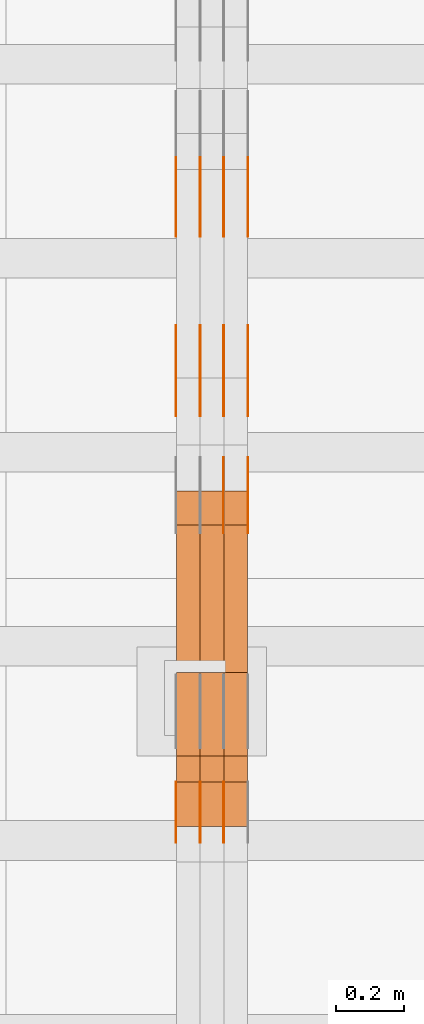
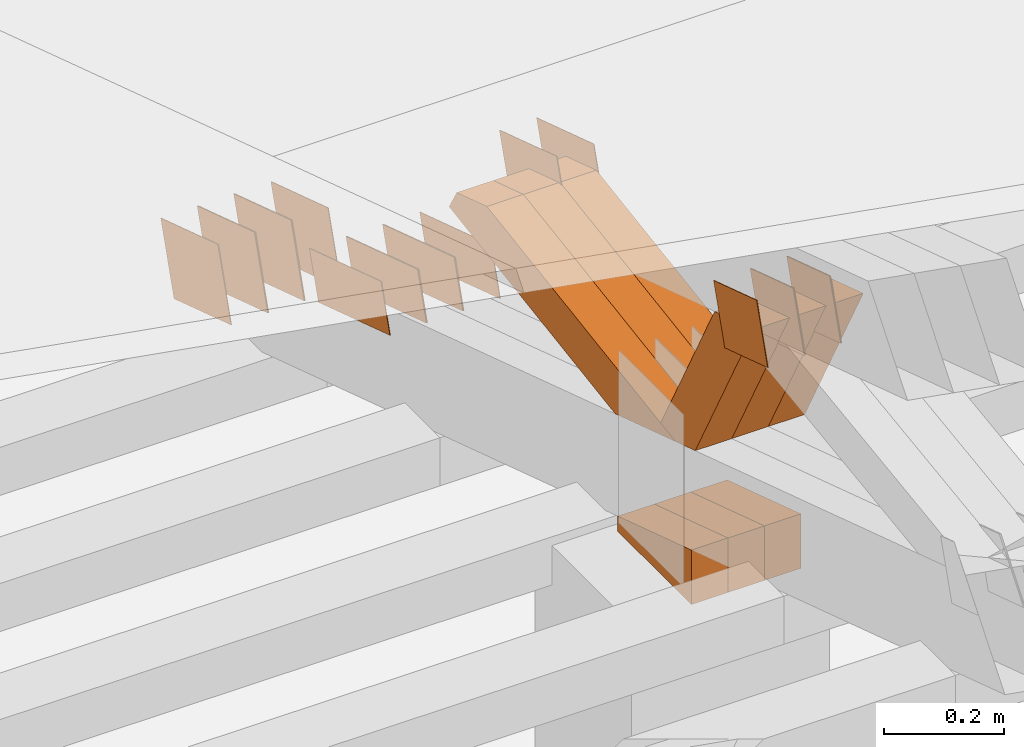
# One storey, part 168 of 385: 28 proxies.
"""IFC2X3 building model written with IfcOpenShell, lengths in millimetres."""

from ifc_helpers import new_model, entity, si_unit, converted_unit, derived_unit, direction, frame, origin, place, context, subcontext, project, spatial, polyline, outline, extrude, source, transform, mapped, material, type_object, type_shapes, element, save


model = new_model("IFC2X3")

# Units and contexts
model_context = context("Model", 3, precision=0.01, world=origin(), true_north=direction((6.12303176911189e-17, 1.0)))
body_context = subcontext(model_context, "Body", "Model", "MODEL_VIEW")
ifc_project = project(units=[si_unit("LENGTHUNIT", "METRE", prefix="MILLI"), si_unit("AREAUNIT", "SQUARE_METRE"), si_unit("VOLUMEUNIT", "CUBIC_METRE"), converted_unit("PLANEANGLEUNIT", "DEGREE", entity("IfcRatioMeasure", 0.0174532925199433), si_unit("PLANEANGLEUNIT", "RADIAN"), dimensions=[0, 0, 0, 0, 0, 0, 0]), si_unit("MASSUNIT", "GRAM", prefix="KILO"), derived_unit("MASSDENSITYUNIT", [(si_unit("MASSUNIT", "GRAM", prefix="KILO"), 1), (si_unit("LENGTHUNIT", "METRE"), -3)]), si_unit("TIMEUNIT", "SECOND"), si_unit("FREQUENCYUNIT", "HERTZ"), si_unit("THERMODYNAMICTEMPERATUREUNIT", "DEGREE_CELSIUS"), derived_unit("THERMALTRANSMITTANCEUNIT", [(si_unit("MASSUNIT", "GRAM", prefix="KILO"), 1), (si_unit("THERMODYNAMICTEMPERATUREUNIT", "KELVIN"), -1), (si_unit("TIMEUNIT", "SECOND"), -3)]), derived_unit("VOLUMETRICFLOWRATEUNIT", [(si_unit("LENGTHUNIT", "METRE"), 3), (si_unit("TIMEUNIT", "SECOND"), -1)]), si_unit("ELECTRICCURRENTUNIT", "AMPERE"), si_unit("ELECTRICVOLTAGEUNIT", "VOLT"), si_unit("POWERUNIT", "WATT"), si_unit("FORCEUNIT", "NEWTON", prefix="KILO"), si_unit("ILLUMINANCEUNIT", "LUX"), si_unit("LUMINOUSFLUXUNIT", "LUMEN"), si_unit("LUMINOUSINTENSITYUNIT", "CANDELA"), derived_unit("USERDEFINED", [(si_unit("MASSUNIT", "GRAM", prefix="KILO"), -1), (si_unit("LENGTHUNIT", "METRE"), -2), (si_unit("TIMEUNIT", "SECOND"), 3), (si_unit("LUMINOUSFLUXUNIT", "LUMEN"), 1)]), derived_unit("LINEARVELOCITYUNIT", [(si_unit("LENGTHUNIT", "METRE"), 1), (si_unit("TIMEUNIT", "SECOND"), -1)]), si_unit("PRESSUREUNIT", "PASCAL"), derived_unit("USERDEFINED", [(si_unit("LENGTHUNIT", "METRE"), -2), (si_unit("MASSUNIT", "GRAM", prefix="KILO"), 1), (si_unit("TIMEUNIT", "SECOND"), -2)])], contexts=[model_context])

# Site, building, storey
site_placement = place(None, origin())
site = spatial("IfcSite", under=ifc_project, at=site_placement, CompositionType="ELEMENT")
building_placement = place(site_placement, origin())
building = spatial("IfcBuilding", under=site, at=building_placement, CompositionType="ELEMENT")
storey_placement = place(building_placement, origin())
storey = spatial("IfcBuildingStorey", under=building, at=storey_placement, Name="Default", CompositionType="ELEMENT", Elevation=0.0)

# Proxies
ifc_material_1 = material(Name="IfcSurfaceStyle #376854")
building_element_proxy_type_1 = type_object("IfcBuildingElementProxyType", PredefinedType="NOTDEFINED", material=ifc_material_1)
shared_shape_1 = source(origin(), body_context, "Body", "SweptSolid", [
    extrude(outline(polyline([(-125.00031378339, -47.9999612158856), (125.000225258022, -47.9999612158856), (124.999811678525, 47.9999612158856), (-124.999723153156, 47.9999612158856), (-125.00031378339, -47.9999612158856)])), frame((125.000225258022, 48.0000091013474, 0.0), z_axis=(0.0, 0.0, 1.0), x_axis=(-1.0, 0.0, 0.0)), (0.0, 0.0, 1.0), 1.3),
])
type_shapes(building_element_proxy_type_1, [shared_shape_1])
proxy_1_placement = place(building_placement, frame((30386.3, 18456.8597683375, 2657.46691321253), z_axis=(-1.0, 0.0, 0.0), x_axis=(0.0, -0.951056516295124, 0.309016994375039)))
element("IfcBuildingElementProxy", 1, at=proxy_1_placement, inside=storey, type_object=building_element_proxy_type_1, material=ifc_material_1, context=body_context, shape_type="MappedRepresentation", body=[
    mapped(shared_shape_1, transform((0.0, 0.0, 0.0), scale=1.0)),
])
ifc_material_2 = material(Name="IfcSurfaceStyle #376797")
building_element_proxy_type_2 = type_object("IfcBuildingElementProxyType", PredefinedType="NOTDEFINED", material=ifc_material_2)
shared_shape_2 = source(origin(), body_context, "Body", "SweptSolid", [
    extrude(outline(polyline([(-125.00031378339, -47.9999612158856), (125.000225258022, -47.9999612158856), (124.999811678525, 47.9999612158856), (-124.999723153156, 47.9999612158856), (-125.00031378339, -47.9999612158856)])), frame((125.000225258022, 48.0000091013474, 0.0), z_axis=(0.0, 0.0, 1.0), x_axis=(-1.0, 0.0, 0.0)), (0.0, 0.0, 1.0), 1.3),
])
type_shapes(building_element_proxy_type_2, [shared_shape_2])
proxy_2_placement = place(building_placement, frame((30315.0, 18456.8597683375, 2657.46691321253), z_axis=(-1.0, 0.0, 0.0), x_axis=(0.0, -0.951056516295124, 0.309016994375039)))
element("IfcBuildingElementProxy", 2, at=proxy_2_placement, inside=storey, type_object=building_element_proxy_type_2, material=ifc_material_2, context=body_context, shape_type="MappedRepresentation", body=[
    mapped(shared_shape_2, transform((0.0, 0.0, 0.0), scale=1.0)),
])
ifc_material_3 = material(Name="IfcSurfaceStyle #376740")
building_element_proxy_type_3 = type_object("IfcBuildingElementProxyType", PredefinedType="NOTDEFINED", material=ifc_material_3)
shared_shape_3 = source(origin(), body_context, "Body", "SweptSolid", [
    extrude(outline(polyline([(-125.00031378339, -47.9999612158856), (125.000225258022, -47.9999612158856), (124.999811678525, 47.9999612158856), (-124.999723153156, 47.9999612158856), (-125.00031378339, -47.9999612158856)])), frame((125.000225258022, 48.0000091013474, 0.0), z_axis=(0.0, 0.0, 1.0), x_axis=(-1.0, 0.0, 0.0)), (0.0, 0.0, 1.0), 1.3),
])
type_shapes(building_element_proxy_type_3, [shared_shape_3])
proxy_3_placement = place(building_placement, frame((30316.3, 18456.8597683375, 2657.46691321253), z_axis=(-1.0, 0.0, 0.0), x_axis=(0.0, -0.951056516295124, 0.309016994375039)))
element("IfcBuildingElementProxy", 3, at=proxy_3_placement, inside=storey, type_object=building_element_proxy_type_3, material=ifc_material_3, context=body_context, shape_type="MappedRepresentation", body=[
    mapped(shared_shape_3, transform((0.0, 0.0, 0.0), scale=1.0)),
])
ifc_material_4 = material(Name="IfcSurfaceStyle #376683")
building_element_proxy_type_4 = type_object("IfcBuildingElementProxyType", PredefinedType="NOTDEFINED", material=ifc_material_4)
shared_shape_4 = source(origin(), body_context, "Body", "SweptSolid", [
    extrude(outline(polyline([(-125.00031378339, -47.9999612158856), (125.000225258022, -47.9999612158856), (124.999811678525, 47.9999612158856), (-124.999723153156, 47.9999612158856), (-125.00031378339, -47.9999612158856)])), frame((125.000225258022, 48.0000091013474, 0.0), z_axis=(0.0, 0.0, 1.0), x_axis=(-1.0, 0.0, 0.0)), (0.0, 0.0, 1.0), 1.29999999999998),
])
type_shapes(building_element_proxy_type_4, [shared_shape_4])
proxy_4_placement = place(building_placement, frame((30245.0, 18456.8597683375, 2657.46691321253), z_axis=(-1.0, 0.0, 0.0), x_axis=(0.0, -0.951056516295124, 0.309016994375039)))
element("IfcBuildingElementProxy", 4, at=proxy_4_placement, inside=storey, type_object=building_element_proxy_type_4, material=ifc_material_4, context=body_context, shape_type="MappedRepresentation", body=[
    mapped(shared_shape_4, transform((0.0, 0.0, 0.0), scale=1.0)),
])
ifc_material_5 = material(Name="IfcSurfaceStyle #376626")
building_element_proxy_type_5 = type_object("IfcBuildingElementProxyType", PredefinedType="NOTDEFINED", material=ifc_material_5)
shared_shape_5 = source(origin(), body_context, "Body", "SweptSolid", [
    extrude(outline(polyline([(-125.00031378339, -47.9999612158856), (125.000225258022, -47.9999612158856), (124.999811678525, 47.9999612158856), (-124.999723153156, 47.9999612158856), (-125.00031378339, -47.9999612158856)])), frame((125.000225258022, 48.0000091013474, 0.0), z_axis=(0.0, 0.0, 1.0), x_axis=(-1.0, 0.0, 0.0)), (0.0, 0.0, 1.0), 1.29999999999998),
])
type_shapes(building_element_proxy_type_5, [shared_shape_5])
proxy_5_placement = place(building_placement, frame((30246.3, 18456.8597683375, 2657.46691321253), z_axis=(-1.0, 0.0, 0.0), x_axis=(0.0, -0.951056516295124, 0.309016994375039)))
element("IfcBuildingElementProxy", 5, at=proxy_5_placement, inside=storey, type_object=building_element_proxy_type_5, material=ifc_material_5, context=body_context, shape_type="MappedRepresentation", body=[
    mapped(shared_shape_5, transform((0.0, 0.0, 0.0), scale=1.0)),
])
ifc_material_6 = material(Name="IfcSurfaceStyle #376569")
building_element_proxy_type_6 = type_object("IfcBuildingElementProxyType", PredefinedType="NOTDEFINED", material=ifc_material_6)
shared_shape_6 = source(origin(), body_context, "Body", "SweptSolid", [
    extrude(outline(polyline([(-125.00031378339, -47.9999612158856), (125.000225258022, -47.9999612158856), (124.999811678525, 47.9999612158856), (-124.999723153156, 47.9999612158856), (-125.00031378339, -47.9999612158856)])), frame((125.000225258022, 48.0000091013474, 0.0), z_axis=(0.0, 0.0, 1.0), x_axis=(-1.0, 0.0, 0.0)), (0.0, 0.0, 1.0), 1.29999999999998),
])
type_shapes(building_element_proxy_type_6, [shared_shape_6])
proxy_6_placement = place(building_placement, frame((30175.0, 18456.8597683375, 2657.46691321253), z_axis=(-1.0, 0.0, 0.0), x_axis=(0.0, -0.951056516295124, 0.309016994375039)))
element("IfcBuildingElementProxy", 6, at=proxy_6_placement, inside=storey, type_object=building_element_proxy_type_6, material=ifc_material_6, context=body_context, shape_type="MappedRepresentation", body=[
    mapped(shared_shape_6, transform((0.0, 0.0, 0.0), scale=1.0)),
])
ifc_material_7 = material(Name="IfcSurfaceStyle #375144")
building_element_proxy_type_7 = type_object("IfcBuildingElementProxyType", PredefinedType="NOTDEFINED", material=ifc_material_7)
shared_shape_7 = source(origin(), body_context, "Body", "SweptSolid", [
    extrude(outline(polyline([(-99.999796294464, -72.0000050220467), (99.9998768370438, -72.0000050220467), (100.000260677528, 72.0000050220467), (-100.000341220108, 72.0000050220467), (-99.999796294464, -72.0000050220467)])), frame((100.000260677528, 72.0000050220467, 0.0), z_axis=(0.0, 0.0, 1.0), x_axis=(-1.0, 0.0, 0.0)), (0.0, 0.0, 1.0), 1.3),
])
type_shapes(building_element_proxy_type_7, [shared_shape_7])
proxy_7_placement = place(building_placement, frame((30386.3, 18936.3876569477, 2373.90613192527), z_axis=(-1.0, 0.0, 0.0), x_axis=(0.0, -0.951056516295124, 0.309016994375039)))
element("IfcBuildingElementProxy", 7, at=proxy_7_placement, inside=storey, type_object=building_element_proxy_type_7, material=ifc_material_7, context=body_context, shape_type="MappedRepresentation", body=[
    mapped(shared_shape_7, transform((0.0, 0.0, 0.0), scale=1.0)),
])
ifc_material_8 = material(Name="IfcSurfaceStyle #375087")
building_element_proxy_type_8 = type_object("IfcBuildingElementProxyType", PredefinedType="NOTDEFINED", material=ifc_material_8)
shared_shape_8 = source(origin(), body_context, "Body", "SweptSolid", [
    extrude(outline(polyline([(-99.999796294464, -72.0000050220467), (99.9998768370438, -72.0000050220467), (100.000260677528, 72.0000050220467), (-100.000341220108, 72.0000050220467), (-99.999796294464, -72.0000050220467)])), frame((100.000260677528, 72.0000050220467, 0.0), z_axis=(0.0, 0.0, 1.0), x_axis=(-1.0, 0.0, 0.0)), (0.0, 0.0, 1.0), 1.3),
])
type_shapes(building_element_proxy_type_8, [shared_shape_8])
proxy_8_placement = place(building_placement, frame((30315.0, 18936.3876569477, 2373.90613192527), z_axis=(-1.0, 0.0, 0.0), x_axis=(0.0, -0.951056516295124, 0.309016994375039)))
element("IfcBuildingElementProxy", 8, at=proxy_8_placement, inside=storey, type_object=building_element_proxy_type_8, material=ifc_material_8, context=body_context, shape_type="MappedRepresentation", body=[
    mapped(shared_shape_8, transform((0.0, 0.0, 0.0), scale=1.0)),
])
ifc_material_9 = material(Name="IfcSurfaceStyle #375030")
building_element_proxy_type_9 = type_object("IfcBuildingElementProxyType", PredefinedType="NOTDEFINED", material=ifc_material_9)
shared_shape_9 = source(origin(), body_context, "Body", "SweptSolid", [
    extrude(outline(polyline([(-99.999796294464, -72.0000050220467), (99.9998768370438, -72.0000050220467), (100.000260677528, 72.0000050220467), (-100.000341220108, 72.0000050220467), (-99.999796294464, -72.0000050220467)])), frame((100.000260677528, 72.0000050220467, 0.0), z_axis=(0.0, 0.0, 1.0), x_axis=(-1.0, 0.0, 0.0)), (0.0, 0.0, 1.0), 1.3),
])
type_shapes(building_element_proxy_type_9, [shared_shape_9])
proxy_9_placement = place(building_placement, frame((30316.3, 18936.3876569477, 2373.90613192527), z_axis=(-1.0, 0.0, 0.0), x_axis=(0.0, -0.951056516295124, 0.309016994375039)))
element("IfcBuildingElementProxy", 9, at=proxy_9_placement, inside=storey, type_object=building_element_proxy_type_9, material=ifc_material_9, context=body_context, shape_type="MappedRepresentation", body=[
    mapped(shared_shape_9, transform((0.0, 0.0, 0.0), scale=1.0)),
])
ifc_material_10 = material(Name="IfcSurfaceStyle #374973")
building_element_proxy_type_10 = type_object("IfcBuildingElementProxyType", PredefinedType="NOTDEFINED", material=ifc_material_10)
shared_shape_10 = source(origin(), body_context, "Body", "SweptSolid", [
    extrude(outline(polyline([(-99.999796294464, -72.0000050220467), (99.9998768370438, -72.0000050220467), (100.000260677528, 72.0000050220467), (-100.000341220108, 72.0000050220467), (-99.999796294464, -72.0000050220467)])), frame((100.000260677528, 72.0000050220467, 0.0), z_axis=(0.0, 0.0, 1.0), x_axis=(-1.0, 0.0, 0.0)), (0.0, 0.0, 1.0), 1.29999999999998),
])
type_shapes(building_element_proxy_type_10, [shared_shape_10])
proxy_10_placement = place(building_placement, frame((30245.0, 18936.3876569477, 2373.90613192527), z_axis=(-1.0, 0.0, 0.0), x_axis=(0.0, -0.951056516295124, 0.309016994375039)))
element("IfcBuildingElementProxy", 10, at=proxy_10_placement, inside=storey, type_object=building_element_proxy_type_10, material=ifc_material_10, context=body_context, shape_type="MappedRepresentation", body=[
    mapped(shared_shape_10, transform((0.0, 0.0, 0.0), scale=1.0)),
])
ifc_material_11 = material(Name="IfcSurfaceStyle #374916")
building_element_proxy_type_11 = type_object("IfcBuildingElementProxyType", PredefinedType="NOTDEFINED", material=ifc_material_11)
shared_shape_11 = source(origin(), body_context, "Body", "SweptSolid", [
    extrude(outline(polyline([(-99.999796294464, -72.0000050220467), (99.9998768370438, -72.0000050220467), (100.000260677528, 72.0000050220467), (-100.000341220108, 72.0000050220467), (-99.999796294464, -72.0000050220467)])), frame((100.000260677528, 72.0000050220467, 0.0), z_axis=(0.0, 0.0, 1.0), x_axis=(-1.0, 0.0, 0.0)), (0.0, 0.0, 1.0), 1.29999999999998),
])
type_shapes(building_element_proxy_type_11, [shared_shape_11])
proxy_11_placement = place(building_placement, frame((30246.3, 18936.3876569477, 2373.90613192527), z_axis=(-1.0, 0.0, 0.0), x_axis=(0.0, -0.951056516295124, 0.309016994375039)))
element("IfcBuildingElementProxy", 11, at=proxy_11_placement, inside=storey, type_object=building_element_proxy_type_11, material=ifc_material_11, context=body_context, shape_type="MappedRepresentation", body=[
    mapped(shared_shape_11, transform((0.0, 0.0, 0.0), scale=1.0)),
])
ifc_material_12 = material(Name="IfcSurfaceStyle #374859")
building_element_proxy_type_12 = type_object("IfcBuildingElementProxyType", PredefinedType="NOTDEFINED", material=ifc_material_12)
shared_shape_12 = source(origin(), body_context, "Body", "SweptSolid", [
    extrude(outline(polyline([(-99.999796294464, -72.0000050220467), (99.9998768370438, -72.0000050220467), (100.000260677528, 72.0000050220467), (-100.000341220108, 72.0000050220467), (-99.999796294464, -72.0000050220467)])), frame((100.000260677528, 72.0000050220467, 0.0), z_axis=(0.0, 0.0, 1.0), x_axis=(-1.0, 0.0, 0.0)), (0.0, 0.0, 1.0), 1.29999999999999),
])
type_shapes(building_element_proxy_type_12, [shared_shape_12])
proxy_12_placement = place(building_placement, frame((30175.0, 18936.3876569477, 2373.90613192527), z_axis=(-1.0, 0.0, 0.0), x_axis=(0.0, -0.951056516295124, 0.309016994375039)))
element("IfcBuildingElementProxy", 12, at=proxy_12_placement, inside=storey, type_object=building_element_proxy_type_12, material=ifc_material_12, context=body_context, shape_type="MappedRepresentation", body=[
    mapped(shared_shape_12, transform((0.0, 0.0, 0.0), scale=1.0)),
])
ifc_material_13 = material(Name="IfcSurfaceStyle #371325")
building_element_proxy_type_13 = type_object("IfcBuildingElementProxyType", PredefinedType="NOTDEFINED", material=ifc_material_13)
shared_shape_13 = source(origin(), body_context, "Body", "SweptSolid", [
    extrude(outline(polyline([(-74.9998605591058, -59.9999264677524), (74.999875428623, -59.9999264677524), (74.9998605591068, 59.9999264677524), (-74.9998754286239, 59.9999264677524), (-74.9998605591058, -59.9999264677524)])), frame((75.0002460484325, 60.0000016373508, 0.0), z_axis=(0.0, 0.0, 1.0), x_axis=(-1.0, 0.0, 0.0)), (0.0, 0.0, 1.0), 1.3),
])
type_shapes(building_element_proxy_type_13, [shared_shape_13])
proxy_13_placement = place(building_placement, frame((30315.0, 17107.0599369346, 3383.82825001787), z_axis=(-1.0, 0.0, 0.0), x_axis=(0.0, -0.951056516295154, 0.309016994374948)))
element("IfcBuildingElementProxy", 13, at=proxy_13_placement, inside=storey, type_object=building_element_proxy_type_13, material=ifc_material_13, context=body_context, shape_type="MappedRepresentation", body=[
    mapped(shared_shape_13, transform((0.0, 0.0, 0.0), scale=1.0)),
])
ifc_material_14 = material(Name="IfcSurfaceStyle #371268")
building_element_proxy_type_14 = type_object("IfcBuildingElementProxyType", PredefinedType="NOTDEFINED", material=ifc_material_14)
shared_shape_14 = source(origin(), body_context, "Body", "SweptSolid", [
    extrude(outline(polyline([(-74.9998605591058, -59.9999264677524), (74.999875428623, -59.9999264677524), (74.9998605591068, 59.9999264677524), (-74.9998754286239, 59.9999264677524), (-74.9998605591058, -59.9999264677524)])), frame((75.0002460484325, 60.0000016373508, 0.0), z_axis=(0.0, 0.0, 1.0), x_axis=(-1.0, 0.0, 0.0)), (0.0, 0.0, 1.0), 1.3),
])
type_shapes(building_element_proxy_type_14, [shared_shape_14])
proxy_14_placement = place(building_placement, frame((30316.3, 17107.0599369346, 3383.82825001787), z_axis=(-1.0, 0.0, 0.0), x_axis=(0.0, -0.951056516295154, 0.309016994374948)))
element("IfcBuildingElementProxy", 14, at=proxy_14_placement, inside=storey, type_object=building_element_proxy_type_14, material=ifc_material_14, context=body_context, shape_type="MappedRepresentation", body=[
    mapped(shared_shape_14, transform((0.0, 0.0, 0.0), scale=1.0)),
])
ifc_material_15 = material(Name="IfcSurfaceStyle #371211")
building_element_proxy_type_15 = type_object("IfcBuildingElementProxyType", PredefinedType="NOTDEFINED", material=ifc_material_15)
shared_shape_15 = source(origin(), body_context, "Body", "SweptSolid", [
    extrude(outline(polyline([(-74.9998605591058, -59.9999264677524), (74.999875428623, -59.9999264677524), (74.9998605591068, 59.9999264677524), (-74.9998754286239, 59.9999264677524), (-74.9998605591058, -59.9999264677524)])), frame((75.0002460484325, 60.0000016373508, 0.0), z_axis=(0.0, 0.0, 1.0), x_axis=(-1.0, 0.0, 0.0)), (0.0, 0.0, 1.0), 1.29999999999999),
])
type_shapes(building_element_proxy_type_15, [shared_shape_15])
proxy_15_placement = place(building_placement, frame((30245.0, 17107.0599369346, 3383.82825001787), z_axis=(-1.0, 0.0, 0.0), x_axis=(0.0, -0.951056516295154, 0.309016994374948)))
element("IfcBuildingElementProxy", 15, at=proxy_15_placement, inside=storey, type_object=building_element_proxy_type_15, material=ifc_material_15, context=body_context, shape_type="MappedRepresentation", body=[
    mapped(shared_shape_15, transform((0.0, 0.0, 0.0), scale=1.0)),
])
ifc_material_16 = material(Name="IfcSurfaceStyle #371154")
building_element_proxy_type_16 = type_object("IfcBuildingElementProxyType", PredefinedType="NOTDEFINED", material=ifc_material_16)
shared_shape_16 = source(origin(), body_context, "Body", "SweptSolid", [
    extrude(outline(polyline([(-74.9998605591058, -59.9999264677524), (74.999875428623, -59.9999264677524), (74.9998605591068, 59.9999264677524), (-74.9998754286239, 59.9999264677524), (-74.9998605591058, -59.9999264677524)])), frame((75.0002460484325, 60.0000016373508, 0.0), z_axis=(0.0, 0.0, 1.0), x_axis=(-1.0, 0.0, 0.0)), (0.0, 0.0, 1.0), 1.29999999999999),
])
type_shapes(building_element_proxy_type_16, [shared_shape_16])
proxy_16_placement = place(building_placement, frame((30246.3, 17107.0599369346, 3383.82825001787), z_axis=(-1.0, 0.0, 0.0), x_axis=(0.0, -0.951056516295154, 0.309016994374948)))
element("IfcBuildingElementProxy", 16, at=proxy_16_placement, inside=storey, type_object=building_element_proxy_type_16, material=ifc_material_16, context=body_context, shape_type="MappedRepresentation", body=[
    mapped(shared_shape_16, transform((0.0, 0.0, 0.0), scale=1.0)),
])
ifc_material_17 = material(Name="IfcSurfaceStyle #371097")
building_element_proxy_type_17 = type_object("IfcBuildingElementProxyType", PredefinedType="NOTDEFINED", material=ifc_material_17)
shared_shape_17 = source(origin(), body_context, "Body", "SweptSolid", [
    extrude(outline(polyline([(-74.9998605591058, -59.9999264677524), (74.999875428623, -59.9999264677524), (74.9998605591068, 59.9999264677524), (-74.9998754286239, 59.9999264677524), (-74.9998605591058, -59.9999264677524)])), frame((75.0002460484325, 60.0000016373508, 0.0), z_axis=(0.0, 0.0, 1.0), x_axis=(-1.0, 0.0, 0.0)), (0.0, 0.0, 1.0), 1.29999999999999),
])
type_shapes(building_element_proxy_type_17, [shared_shape_17])
proxy_17_placement = place(building_placement, frame((30175.0, 17107.0599369346, 3383.82825001787), z_axis=(-1.0, 0.0, 0.0), x_axis=(0.0, -0.951056516295154, 0.309016994374948)))
element("IfcBuildingElementProxy", 17, at=proxy_17_placement, inside=storey, type_object=building_element_proxy_type_17, material=ifc_material_17, context=body_context, shape_type="MappedRepresentation", body=[
    mapped(shared_shape_17, transform((0.0, 0.0, 0.0), scale=1.0)),
])
ifc_material_18 = material(Name="IfcSurfaceStyle #370698")
building_element_proxy_type_18 = type_object("IfcBuildingElementProxyType", PredefinedType="NOTDEFINED", material=ifc_material_18)
shared_shape_18 = source(origin(), body_context, "Body", "SweptSolid", [
    extrude(outline(polyline([(-99.9999427841299, -54.0000599375792), (99.9996549037756, -54.0000599375792), (100.000407167194, 54.0000599375792), (-100.00011928684, 54.0000599375792), (-99.9999427841299, -54.0000599375792)])), frame((100.000407167194, 54.0000599375792, 0.0), z_axis=(0.0, 0.0, 1.0), x_axis=(-1.0, 0.0, 0.0)), (0.0, 0.0, 1.0), 1.3),
])
type_shapes(building_element_proxy_type_18, [shared_shape_18])
proxy_18_placement = place(building_placement, frame((30386.3, 18065.0682492591, 3072.55239547302), z_axis=(-1.0, 0.0, 0.0), x_axis=(0.0, -0.951056516295154, 0.309016994374948)))
element("IfcBuildingElementProxy", 18, at=proxy_18_placement, inside=storey, type_object=building_element_proxy_type_18, material=ifc_material_18, context=body_context, shape_type="MappedRepresentation", body=[
    mapped(shared_shape_18, transform((0.0, 0.0, 0.0), scale=1.0)),
])
ifc_material_19 = material(Name="IfcSurfaceStyle #370641")
building_element_proxy_type_19 = type_object("IfcBuildingElementProxyType", PredefinedType="NOTDEFINED", material=ifc_material_19)
shared_shape_19 = source(origin(), body_context, "Body", "SweptSolid", [
    extrude(outline(polyline([(-99.9999427841299, -54.0000599375792), (99.9996549037756, -54.0000599375792), (100.000407167194, 54.0000599375792), (-100.00011928684, 54.0000599375792), (-99.9999427841299, -54.0000599375792)])), frame((100.000407167194, 54.0000599375792, 0.0), z_axis=(0.0, 0.0, 1.0), x_axis=(-1.0, 0.0, 0.0)), (0.0, 0.0, 1.0), 1.3),
])
type_shapes(building_element_proxy_type_19, [shared_shape_19])
proxy_19_placement = place(building_placement, frame((30315.0, 18065.0682492591, 3072.55239547302), z_axis=(-1.0, 0.0, 0.0), x_axis=(0.0, -0.951056516295154, 0.309016994374948)))
element("IfcBuildingElementProxy", 19, at=proxy_19_placement, inside=storey, type_object=building_element_proxy_type_19, material=ifc_material_19, context=body_context, shape_type="MappedRepresentation", body=[
    mapped(shared_shape_19, transform((0.0, 0.0, 0.0), scale=1.0)),
])
ifc_material_20 = material(Name="IfcSurfaceStyle #363093")
building_element_proxy_type_20 = type_object("IfcBuildingElementProxyType", Name="T1-E1 363091", PredefinedType="NOTDEFINED", material=ifc_material_20)
shared_shape_20 = source(origin(), body_context, "Body", "SweptSolid", [
    extrude(outline(polyline([(4.4675903320374, -122.500000000001), (35.3350219726624, -122.500000000001), (35.3350219726501, 122.500000000001), (-75.1376342773499, 122.500000000001), (4.4675903320374, -122.500000000001)])), frame((35.3350219726624, 122.50000005215, 0.0), z_axis=(0.0, 0.0, 1.0), x_axis=(-1.0, 0.0, 0.0)), (0.0, 0.0, 1.0), 70.0),
])
type_shapes(building_element_proxy_type_20, [shared_shape_20])
proxy_20_placement = place(building_placement, frame((30385.0, 17220.0, 2794.30932617186), z_axis=(-1.0, 0.0, 0.0), x_axis=(0.0, 0.0, 1.0)))
element("IfcBuildingElementProxy", 20, at=proxy_20_placement, inside=storey, type_object=building_element_proxy_type_20, material=ifc_material_20, Name="T1-E1", context=body_context, shape_type="MappedRepresentation", body=[
    mapped(shared_shape_20, transform((0.0, 0.0, 0.0), scale=1.0)),
])
ifc_material_21 = material(Name="IfcSurfaceStyle #363036")
building_element_proxy_type_21 = type_object("IfcBuildingElementProxyType", Name="T1-E1 363034", PredefinedType="NOTDEFINED", material=ifc_material_21)
shared_shape_21 = source(origin(), body_context, "Body", "SweptSolid", [
    extrude(outline(polyline([(4.4675903320374, -122.500000000001), (35.3350219726624, -122.500000000001), (35.3350219726501, 122.500000000001), (-75.1376342773499, 122.500000000001), (4.4675903320374, -122.500000000001)])), frame((35.3350219726624, 122.50000005215, 0.0), z_axis=(0.0, 0.0, 1.0), x_axis=(-1.0, 0.0, 0.0)), (0.0, 0.0, 1.0), 70.0),
])
type_shapes(building_element_proxy_type_21, [shared_shape_21])
proxy_21_placement = place(building_placement, frame((30315.0, 17220.0, 2794.30932617186), z_axis=(-1.0, 0.0, 0.0), x_axis=(0.0, 0.0, 1.0)))
element("IfcBuildingElementProxy", 21, at=proxy_21_placement, inside=storey, type_object=building_element_proxy_type_21, material=ifc_material_21, Name="T1-E1", context=body_context, shape_type="MappedRepresentation", body=[
    mapped(shared_shape_21, transform((0.0, 0.0, 0.0), scale=1.0)),
])
ifc_material_22 = material(Name="IfcSurfaceStyle #362979")
building_element_proxy_type_22 = type_object("IfcBuildingElementProxyType", Name="T1-E1 362977", PredefinedType="NOTDEFINED", material=ifc_material_22)
shared_shape_22 = source(origin(), body_context, "Body", "SweptSolid", [
    extrude(outline(polyline([(4.4675903320374, -122.500000000001), (35.3350219726624, -122.500000000001), (35.3350219726501, 122.500000000001), (-75.1376342773499, 122.500000000001), (4.4675903320374, -122.500000000001)])), frame((35.3350219726624, 122.50000005215, 0.0), z_axis=(0.0, 0.0, 1.0), x_axis=(-1.0, 0.0, 0.0)), (0.0, 0.0, 1.0), 70.0),
])
type_shapes(building_element_proxy_type_22, [shared_shape_22])
proxy_22_placement = place(building_placement, frame((30245.0, 17220.0, 2794.30932617186), z_axis=(-1.0, 0.0, 0.0), x_axis=(0.0, 0.0, 1.0)))
element("IfcBuildingElementProxy", 22, at=proxy_22_placement, inside=storey, type_object=building_element_proxy_type_22, material=ifc_material_22, Name="T1-E1", context=body_context, shape_type="MappedRepresentation", body=[
    mapped(shared_shape_22, transform((0.0, 0.0, 0.0), scale=1.0)),
])
ifc_material_23 = material(Name="IfcSurfaceStyle #361338")
building_element_proxy_type_23 = type_object("IfcBuildingElementProxyType", Name="T1-W39 361336", PredefinedType="NOTDEFINED", material=ifc_material_23)
shared_shape_23 = source(origin(), body_context, "Body", "SweptSolid", [
    extrude(outline(polyline([(-191.519946663886, -47.499928106579), (188.32936223763, -47.499928106579), (171.597440144109, 0.000249483340993841), (122.102882529753, 47.4998033649085), (-290.509738247605, 47.4998033649085), (-191.519946663886, -47.499928106579)])), frame((188.329593252001, 47.499957247623, 0.0), z_axis=(0.0, 0.0, 1.0), x_axis=(-1.0, 0.0, 0.0)), (0.0, 0.0, 1.0), 70.0),
])
type_shapes(building_element_proxy_type_23, [shared_shape_23])
proxy_23_placement = place(building_placement, frame((30385.0, 17238.5876916597, 3055.56121424762), z_axis=(-1.0, 0.0, 0.0), x_axis=(0.0, -0.472216932390777, 0.881482370080902)))
element("IfcBuildingElementProxy", 23, at=proxy_23_placement, inside=storey, type_object=building_element_proxy_type_23, material=ifc_material_23, Name="T1-W39", context=body_context, shape_type="MappedRepresentation", body=[
    mapped(shared_shape_23, transform((0.0, 0.0, 0.0), scale=1.0)),
])
ifc_material_24 = material(Name="IfcSurfaceStyle #361272")
building_element_proxy_type_24 = type_object("IfcBuildingElementProxyType", Name="T1-W39 361270", PredefinedType="NOTDEFINED", material=ifc_material_24)
shared_shape_24 = source(origin(), body_context, "Body", "SweptSolid", [
    extrude(outline(polyline([(-191.519946663886, -47.499928106579), (188.32936223763, -47.499928106579), (171.597440144109, 0.000249483340993841), (122.102882529753, 47.4998033649085), (-290.509738247605, 47.4998033649085), (-191.519946663886, -47.499928106579)])), frame((188.329593252001, 47.499957247623, 0.0), z_axis=(0.0, 0.0, 1.0), x_axis=(-1.0, 0.0, 0.0)), (0.0, 0.0, 1.0), 70.0),
])
type_shapes(building_element_proxy_type_24, [shared_shape_24])
proxy_24_placement = place(building_placement, frame((30315.0, 17238.5876916597, 3055.56121424762), z_axis=(-1.0, 0.0, 0.0), x_axis=(0.0, -0.472216932390777, 0.881482370080902)))
element("IfcBuildingElementProxy", 24, at=proxy_24_placement, inside=storey, type_object=building_element_proxy_type_24, material=ifc_material_24, Name="T1-W39", context=body_context, shape_type="MappedRepresentation", body=[
    mapped(shared_shape_24, transform((0.0, 0.0, 0.0), scale=1.0)),
])
ifc_material_25 = material(Name="IfcSurfaceStyle #361206")
building_element_proxy_type_25 = type_object("IfcBuildingElementProxyType", Name="T1-W39 361204", PredefinedType="NOTDEFINED", material=ifc_material_25)
shared_shape_25 = source(origin(), body_context, "Body", "SweptSolid", [
    extrude(outline(polyline([(-191.519946663886, -47.499928106579), (188.32936223763, -47.499928106579), (171.597440144109, 0.000249483340993841), (122.102882529753, 47.4998033649085), (-290.509738247605, 47.4998033649085), (-191.519946663886, -47.499928106579)])), frame((188.329593252001, 47.499957247623, 0.0), z_axis=(0.0, 0.0, 1.0), x_axis=(-1.0, 0.0, 0.0)), (0.0, 0.0, 1.0), 70.0),
])
type_shapes(building_element_proxy_type_25, [shared_shape_25])
proxy_25_placement = place(building_placement, frame((30245.0, 17238.5876916597, 3055.56121424762), z_axis=(-1.0, 0.0, 0.0), x_axis=(0.0, -0.472216932390777, 0.881482370080902)))
element("IfcBuildingElementProxy", 25, at=proxy_25_placement, inside=storey, type_object=building_element_proxy_type_25, material=ifc_material_25, Name="T1-W39", context=body_context, shape_type="MappedRepresentation", body=[
    mapped(shared_shape_25, transform((0.0, 0.0, 0.0), scale=1.0)),
])
ifc_material_26 = material(Name="IfcSurfaceStyle #360942")
building_element_proxy_type_26 = type_object("IfcBuildingElementProxyType", Name="T1-W10 360940", PredefinedType="NOTDEFINED", material=ifc_material_26)
shared_shape_26 = source(origin(), body_context, "Body", "SweptSolid", [
    extrude(outline(polyline([(-459.546036710757, -47.5000436364511), (174.689450869018, -47.5000436364511), (268.831081103959, 0.00011114562912502), (287.286350706789, 47.4999880636365), (-271.260845969009, 47.4999880636366), (-459.546036710757, -47.5000436364511)])), frame((287.286768781132, 47.5001637448091, 0.0), z_axis=(0.0, 0.0, 1.0), x_axis=(-1.0, 0.0, 0.0)), (0.0, 0.0, 1.0), 70.0),
])
type_shapes(building_element_proxy_type_26, [shared_shape_26])
proxy_26_placement = place(building_placement, frame((30385.0, 18025.1410649788, 3112.76453857986), z_axis=(-1.0, 0.0, 0.0), x_axis=(0.0, -0.988299196256916, -0.152527698068035)))
element("IfcBuildingElementProxy", 26, at=proxy_26_placement, inside=storey, type_object=building_element_proxy_type_26, material=ifc_material_26, Name="T1-W10", context=body_context, shape_type="MappedRepresentation", body=[
    mapped(shared_shape_26, transform((0.0, 0.0, 0.0), scale=1.0)),
])
ifc_material_27 = material(Name="IfcSurfaceStyle #360876")
building_element_proxy_type_27 = type_object("IfcBuildingElementProxyType", Name="T1-W10 360874", PredefinedType="NOTDEFINED", material=ifc_material_27)
shared_shape_27 = source(origin(), body_context, "Body", "SweptSolid", [
    extrude(outline(polyline([(-459.546036710757, -47.5000436364511), (174.689450869018, -47.5000436364511), (268.831081103959, 0.00011114562912502), (287.286350706789, 47.4999880636365), (-271.260845969009, 47.4999880636366), (-459.546036710757, -47.5000436364511)])), frame((287.286768781132, 47.5001637448091, 0.0), z_axis=(0.0, 0.0, 1.0), x_axis=(-1.0, 0.0, 0.0)), (0.0, 0.0, 1.0), 70.0),
])
type_shapes(building_element_proxy_type_27, [shared_shape_27])
proxy_27_placement = place(building_placement, frame((30315.0, 18025.1410649788, 3112.76453857986), z_axis=(-1.0, 0.0, 0.0), x_axis=(0.0, -0.988299196256916, -0.152527698068035)))
element("IfcBuildingElementProxy", 27, at=proxy_27_placement, inside=storey, type_object=building_element_proxy_type_27, material=ifc_material_27, Name="T1-W10", context=body_context, shape_type="MappedRepresentation", body=[
    mapped(shared_shape_27, transform((0.0, 0.0, 0.0), scale=1.0)),
])
ifc_material_28 = material(Name="IfcSurfaceStyle #360810")
building_element_proxy_type_28 = type_object("IfcBuildingElementProxyType", Name="T1-W10 360808", PredefinedType="NOTDEFINED", material=ifc_material_28)
shared_shape_28 = source(origin(), body_context, "Body", "SweptSolid", [
    extrude(outline(polyline([(-459.546036710757, -47.5000436364511), (174.689450869018, -47.5000436364511), (268.831081103959, 0.00011114562912502), (287.286350706789, 47.4999880636365), (-271.260845969009, 47.4999880636366), (-459.546036710757, -47.5000436364511)])), frame((287.286768781132, 47.5001637448091, 0.0), z_axis=(0.0, 0.0, 1.0), x_axis=(-1.0, 0.0, 0.0)), (0.0, 0.0, 1.0), 70.0),
])
type_shapes(building_element_proxy_type_28, [shared_shape_28])
proxy_28_placement = place(building_placement, frame((30245.0, 18025.1410649788, 3112.76453857986), z_axis=(-1.0, 0.0, 0.0), x_axis=(0.0, -0.988299196256916, -0.152527698068035)))
element("IfcBuildingElementProxy", 28, at=proxy_28_placement, inside=storey, type_object=building_element_proxy_type_28, material=ifc_material_28, Name="T1-W10", context=body_context, shape_type="MappedRepresentation", body=[
    mapped(shared_shape_28, transform((0.0, 0.0, 0.0), scale=1.0)),
])

save(model, "model.ifc")
